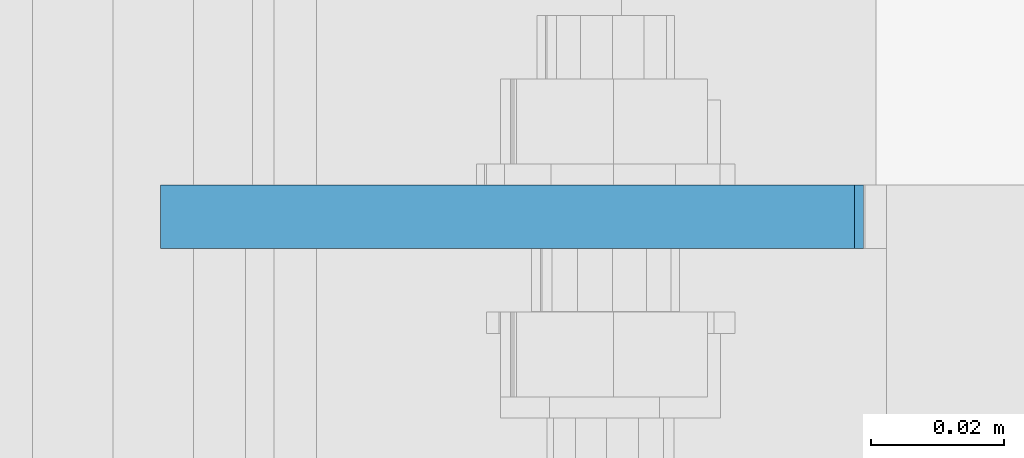
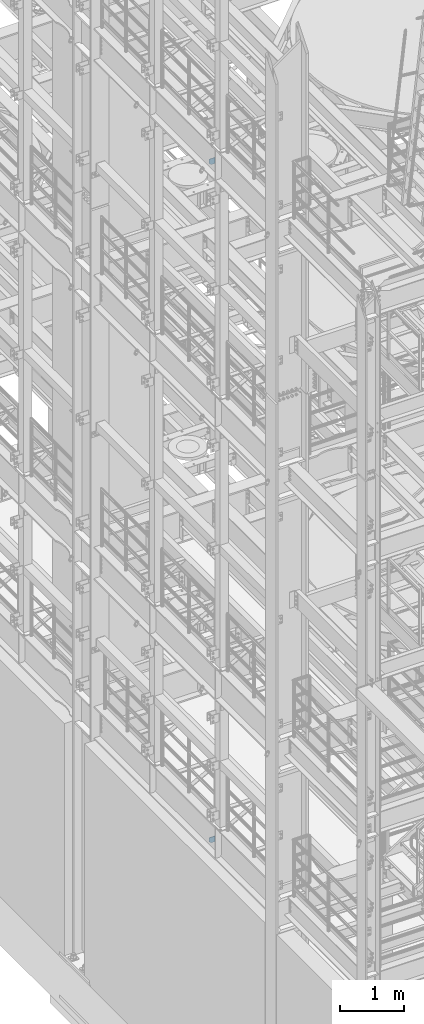
# One storey, part 1480 of 1876: 2 plates, 2 elements without a shape of their own.
"""IFC2X3 building model written with IfcOpenShell, lengths in millimetres."""

from ifc_helpers import new_model, si_unit, frame, origin_with_axes, place, context, subcontext, project, spatial, faceted_brep, material, type_object, element, aggregate, save


model = new_model("IFC2X3")

# Units and contexts
model_context = context("Model", 3, precision=1e-05, world=origin_with_axes())
body_context = subcontext(model_context, "Body", "Model", "MODEL_VIEW")
ifc_project = project(units=[si_unit("LENGTHUNIT", "METRE", prefix="MILLI"), si_unit("AREAUNIT", "SQUARE_METRE"), si_unit("VOLUMEUNIT", "CUBIC_METRE"), si_unit("MASSUNIT", "GRAM", prefix="KILO"), si_unit("TIMEUNIT", "SECOND"), si_unit("PLANEANGLEUNIT", "RADIAN"), si_unit("SOLIDANGLEUNIT", "STERADIAN"), si_unit("THERMODYNAMICTEMPERATUREUNIT", "DEGREE_CELSIUS"), si_unit("LUMINOUSINTENSITYUNIT", "LUMEN")], contexts=[model_context])

# Site, building, storey
site_placement = place(None, origin_with_axes())
site = spatial("IfcSite", under=ifc_project, at=site_placement, CompositionType="ELEMENT")
building_placement = place(site_placement, origin_with_axes())
building = spatial("IfcBuilding", under=site, at=building_placement, Name="Undefined", CompositionType="ELEMENT")
storey_placement = place(building_placement, origin_with_axes())
storey = spatial("IfcBuildingStorey", under=building, at=storey_placement, Name="Undefined", CompositionType="ELEMENT", Elevation=0.0)

# Assembly, plate
assembly_1_placement = place(storey_placement, origin_with_axes())
assembly_1 = element("IfcElementAssembly", 1, at=assembly_1_placement, inside=storey, Name="BEAM", AssemblyPlace="NOTDEFINED", PredefinedType="RIGID_FRAME")
ifc_material = material(Name="STEEL/A36")
plate_type_1 = type_object("IfcPlateType", PredefinedType="NOTDEFINED")
plate_1_placement = place(assembly_1_placement, frame((111.128498160898, -2138.3625, 17386.3), z_axis=(-1.0, 0.0, 0.0), x_axis=(0.0, 0.0, 1.0)))
plate_1 = element("IfcPlate", 2, at=plate_1_placement, type_object=plate_type_1, material=ifc_material, Name="PLATE", context=body_context, shape_type="Brep", body=[
    faceted_brep([(0.0, -4.76249999999982, 0.0), (0.0, -4.76249999999982, 72.234748840332), (0.0, 4.76249999999982, 72.234748840332), (0.0, 4.76249999999982, 0.0), (31.75, -4.76249999999982, 103.984748840332), (31.75, 4.76249999999982, 103.984748840332), (111.653274536133, -4.76249999999982, 103.984748840332), (111.653274536133, 4.76249999999982, 103.984748840332), (111.653274536133, -4.76249999999982, 0.0), (111.653274536133, 4.76249999999982, 0.0)], [[[0, 1, 2, 3]], [[1, 4, 5, 2]], [[4, 6, 7, 5]], [[6, 8, 9, 7]], [[8, 0, 3, 9]], [[5, 7, 9, 3, 2]], [[8, 6, 4, 1, 0]]]),
])
aggregate(assembly_1, [plate_1])

assembly_2_placement = place(storey_placement, origin_with_axes())
assembly_2 = element("IfcElementAssembly", 3, at=assembly_2_placement, inside=storey, Name="BEAM", AssemblyPlace="NOTDEFINED", PredefinedType="RIGID_FRAME")
plate_type_2 = type_object("IfcPlateType", PredefinedType="NOTDEFINED")
plate_2_placement = place(assembly_2_placement, frame((112.451000275038, -2138.3625, 4637.38699830036), z_axis=(0.0, 0.0, -1.0), x_axis=(-1.0, 0.0, 0.0)))
plate_2 = element("IfcPlate", 4, at=plate_2_placement, type_object=plate_type_2, material=ifc_material, Name="PLATE", context=body_context, shape_type="Brep", body=[
    faceted_brep([(0.0, -4.76249999999982, 0.0), (0.0, -4.76249999999999, 103.486999511719), (0.0, 4.76249999999999, 103.486999511719), (0.0, 4.76249999999982, 0.0), (73.5572509765625, -4.76249999999999, 103.486999511719), (73.5572509765625, 4.76249999999999, 103.486999511719), (105.307250976562, -4.76249999999999, 71.7369995117188), (105.307250976562, 4.76249999999999, 71.7369995117188), (105.307250976562, -4.76249999999999, 0.0), (105.307250976562, 4.76249999999999, 0.0)], [[[0, 1, 2, 3]], [[1, 4, 5, 2]], [[4, 6, 7, 5]], [[6, 8, 9, 7]], [[8, 0, 3, 9]], [[5, 7, 9, 3, 2]], [[8, 6, 4, 1, 0]]]),
])
aggregate(assembly_2, [plate_2])

save(model, "model.ifc")
